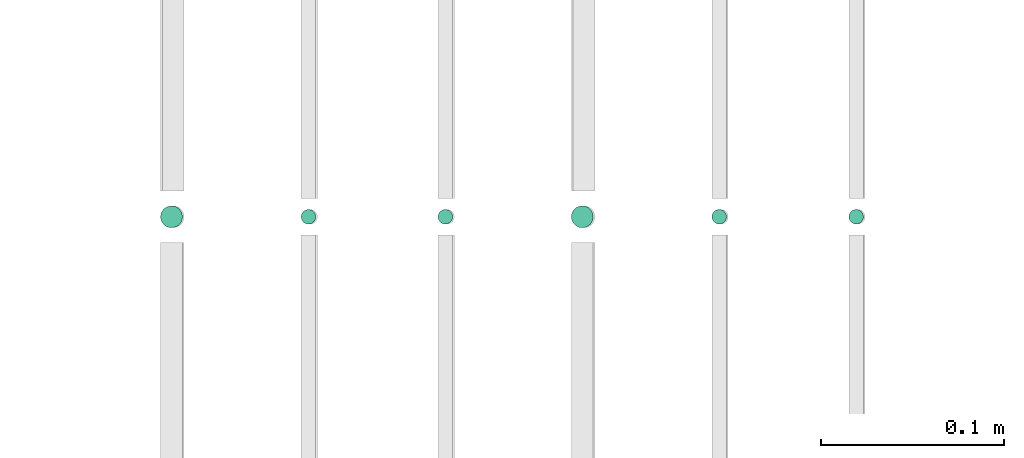
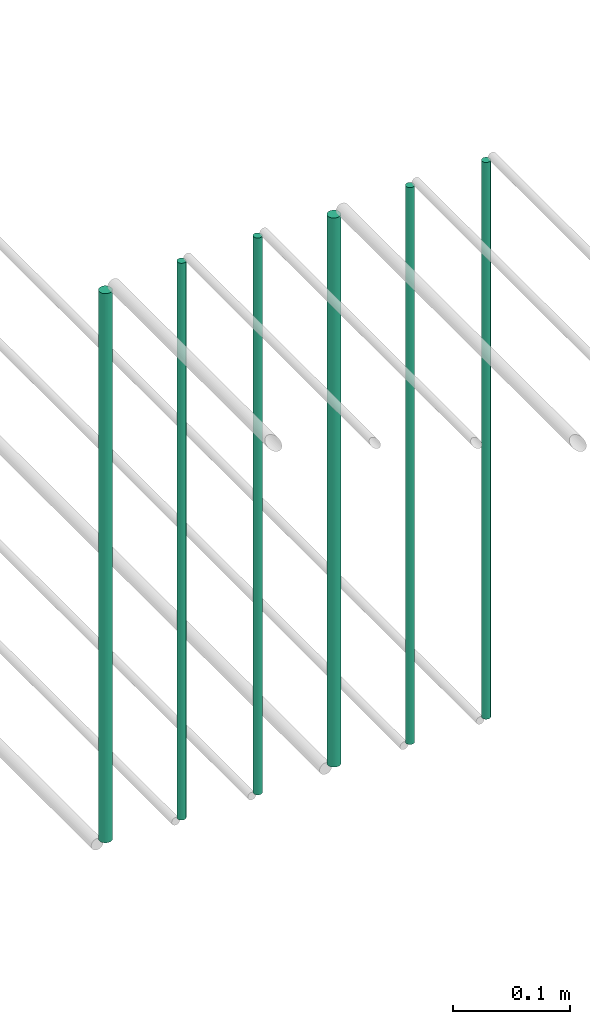
# One storey, part 197 of 331: 6 flow segments.
"""IFC2X3 building model written with IfcOpenShell, lengths in millimetres."""

from ifc_helpers import new_model, entity, si_unit, converted_unit, derived_unit, direction, frame, origin, origin_2d_with_axis, place, context, subcontext, project, spatial, circle, extrude, type_object, element, save


model = new_model("IFC2X3")

# Units and contexts
model_context = context("Model", 3, precision=0.01, world=origin(), true_north=direction((6.12303176911189e-17, 1.0)))
body_context = subcontext(model_context, "Body", "Model", "MODEL_VIEW")
ifc_project = project(units=[si_unit("LENGTHUNIT", "METRE", prefix="MILLI"), si_unit("AREAUNIT", "SQUARE_METRE"), si_unit("VOLUMEUNIT", "CUBIC_METRE"), converted_unit("PLANEANGLEUNIT", "DEGREE", entity("IfcRatioMeasure", 0.0174532925199433), si_unit("PLANEANGLEUNIT", "RADIAN"), dimensions=[0, 0, 0, 0, 0, 0, 0]), si_unit("MASSUNIT", "GRAM", prefix="KILO"), derived_unit("MASSDENSITYUNIT", [(si_unit("MASSUNIT", "GRAM", prefix="KILO"), 1), (si_unit("LENGTHUNIT", "METRE"), -3)]), derived_unit("MOMENTOFINERTIAUNIT", [(si_unit("LENGTHUNIT", "METRE"), 4)]), si_unit("TIMEUNIT", "SECOND"), si_unit("FREQUENCYUNIT", "HERTZ"), si_unit("THERMODYNAMICTEMPERATUREUNIT", "DEGREE_CELSIUS"), derived_unit("THERMALTRANSMITTANCEUNIT", [(si_unit("MASSUNIT", "GRAM", prefix="KILO"), 1), (si_unit("THERMODYNAMICTEMPERATUREUNIT", "KELVIN"), -1), (si_unit("TIMEUNIT", "SECOND"), -3)]), derived_unit("VOLUMETRICFLOWRATEUNIT", [(si_unit("LENGTHUNIT", "METRE"), 3), (si_unit("TIMEUNIT", "SECOND"), -1)]), derived_unit("MASSFLOWRATEUNIT", [(si_unit("MASSUNIT", "GRAM", prefix="KILO"), 1), (si_unit("TIMEUNIT", "SECOND"), -1)]), derived_unit("ROTATIONALFREQUENCYUNIT", [(si_unit("TIMEUNIT", "SECOND"), -1)]), si_unit("ELECTRICCURRENTUNIT", "AMPERE"), si_unit("ELECTRICVOLTAGEUNIT", "VOLT"), si_unit("POWERUNIT", "WATT"), si_unit("FORCEUNIT", "NEWTON", prefix="KILO"), si_unit("ILLUMINANCEUNIT", "LUX"), si_unit("LUMINOUSFLUXUNIT", "LUMEN"), si_unit("LUMINOUSINTENSITYUNIT", "CANDELA"), derived_unit("USERDEFINED", [(si_unit("MASSUNIT", "GRAM", prefix="KILO"), -1), (si_unit("LENGTHUNIT", "METRE"), -2), (si_unit("TIMEUNIT", "SECOND"), 3), (si_unit("LUMINOUSFLUXUNIT", "LUMEN"), 1)]), derived_unit("LINEARVELOCITYUNIT", [(si_unit("LENGTHUNIT", "METRE"), 1), (si_unit("TIMEUNIT", "SECOND"), -1)]), si_unit("PRESSUREUNIT", "PASCAL"), derived_unit("USERDEFINED", [(si_unit("LENGTHUNIT", "METRE"), -2), (si_unit("MASSUNIT", "GRAM", prefix="KILO"), 1), (si_unit("TIMEUNIT", "SECOND"), -2)]), derived_unit("LINEARFORCEUNIT", [(si_unit("MASSUNIT", "GRAM", prefix="KILO"), 1), (si_unit("LENGTHUNIT", "METRE"), 1), (si_unit("TIMEUNIT", "SECOND"), -2), (si_unit("LENGTHUNIT", "METRE"), -1)]), derived_unit("PLANARFORCEUNIT", [(si_unit("MASSUNIT", "GRAM", prefix="KILO"), 1), (si_unit("LENGTHUNIT", "METRE"), 1), (si_unit("TIMEUNIT", "SECOND"), -2), (si_unit("LENGTHUNIT", "METRE"), -2)])], contexts=[model_context])

# Site, building, storey
site_placement = place(None, frame((0.0, -0.00077364408347762, 0.0)))
site = spatial("IfcSite", under=ifc_project, at=site_placement, CompositionType="ELEMENT")
building_placement = place(site_placement, origin())
building = spatial("IfcBuilding", under=site, at=building_placement, CompositionType="ELEMENT")
storey_placement = place(building_placement, origin())
storey = spatial("IfcBuildingStorey", under=building, at=storey_placement, CompositionType="ELEMENT", Elevation=0.0)

# Flow segments
pipe_segment_type = type_object("IfcPipeSegmentType", PredefinedType="NOTDEFINED")
flow_segment_1_placement = place(storey_placement, frame((54064.5706481368, 5638.0252915914, 18460.0)))
element("IfcFlowSegment", 1, at=flow_segment_1_placement, inside=storey, type_object=pipe_segment_type, context=body_context, shape_type="SweptSolid", body=[
    extrude(circle(Radius=4.0, at=origin_2d_with_axis()), frame((5.59527223591499, 5.59527223591607, 0.0), z_axis=(0.0, 0.0, 1.0), x_axis=(-1.0, 0.0, 0.0)), (0.0, 0.0, 1.0), 580.000000000015),
])
flow_segment_2_placement = place(storey_placement, frame((53989.5706481368, 5638.0252915914, 18460.0)))
element("IfcFlowSegment", 2, at=flow_segment_2_placement, inside=storey, type_object=pipe_segment_type, context=body_context, shape_type="SweptSolid", body=[
    extrude(circle(Radius=4.0, at=origin_2d_with_axis()), frame((5.59527223591499, 5.59527223591607, 0.0), z_axis=(0.0, 0.0, 1.0), x_axis=(-1.0, 0.0, 0.0)), (0.0, 0.0, 1.0), 580.000000000007),
])
flow_segment_3_placement = place(storey_placement, frame((53912.5706481368, 5636.0252915914, 18464.0)))
element("IfcFlowSegment", 3, at=flow_segment_3_placement, inside=storey, type_object=pipe_segment_type, context=body_context, shape_type="SweptSolid", body=[
    extrude(circle(Radius=6.0, at=origin_2d_with_axis()), frame((7.59527223591454, 7.59527223591562, 0.0), z_axis=(0.0, 0.0, 1.0), x_axis=(-1.0, 0.0, 0.0)), (0.0, 0.0, 1.0), 572.000000000002),
])
flow_segment_4_placement = place(storey_placement, frame((53839.5706481368, 5638.0252915914, 18460.0)))
element("IfcFlowSegment", 4, at=flow_segment_4_placement, inside=storey, type_object=pipe_segment_type, context=body_context, shape_type="SweptSolid", body=[
    extrude(circle(Radius=4.0, at=origin_2d_with_axis()), frame((5.59527223591499, 5.59527223591607, 0.0), z_axis=(0.0, 0.0, 1.0), x_axis=(-1.0, 0.0, 0.0)), (0.0, 0.0, 1.0), 580.000000000015),
])
flow_segment_5_placement = place(storey_placement, frame((53764.5706481368, 5638.0252915914, 18460.0)))
element("IfcFlowSegment", 5, at=flow_segment_5_placement, inside=storey, type_object=pipe_segment_type, context=body_context, shape_type="SweptSolid", body=[
    extrude(circle(Radius=4.0, at=origin_2d_with_axis()), frame((5.59527223591499, 5.59527223591607, 0.0), z_axis=(0.0, 0.0, 1.0), x_axis=(-1.0, 0.0, 0.0)), (0.0, 0.0, 1.0), 580.0),
])
flow_segment_6_placement = place(storey_placement, frame((53687.5706481368, 5636.02529159141, 18464.0)))
element("IfcFlowSegment", 6, at=flow_segment_6_placement, inside=storey, type_object=pipe_segment_type, context=body_context, shape_type="SweptSolid", body=[
    extrude(circle(Radius=6.0, at=origin_2d_with_axis()), frame((7.59527223591454, 7.59527223591562, 0.0), z_axis=(0.0, 0.0, 1.0), x_axis=(-1.0, 0.0, 0.0)), (0.0, 0.0, 1.0), 572.000000000011),
])

save(model, "model.ifc")
